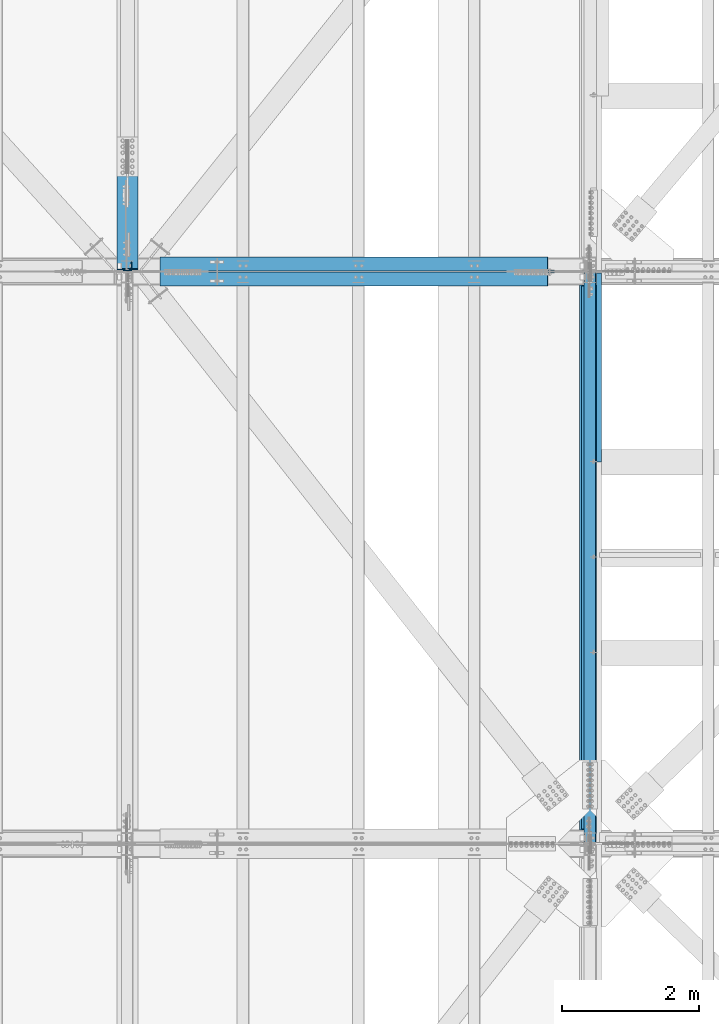
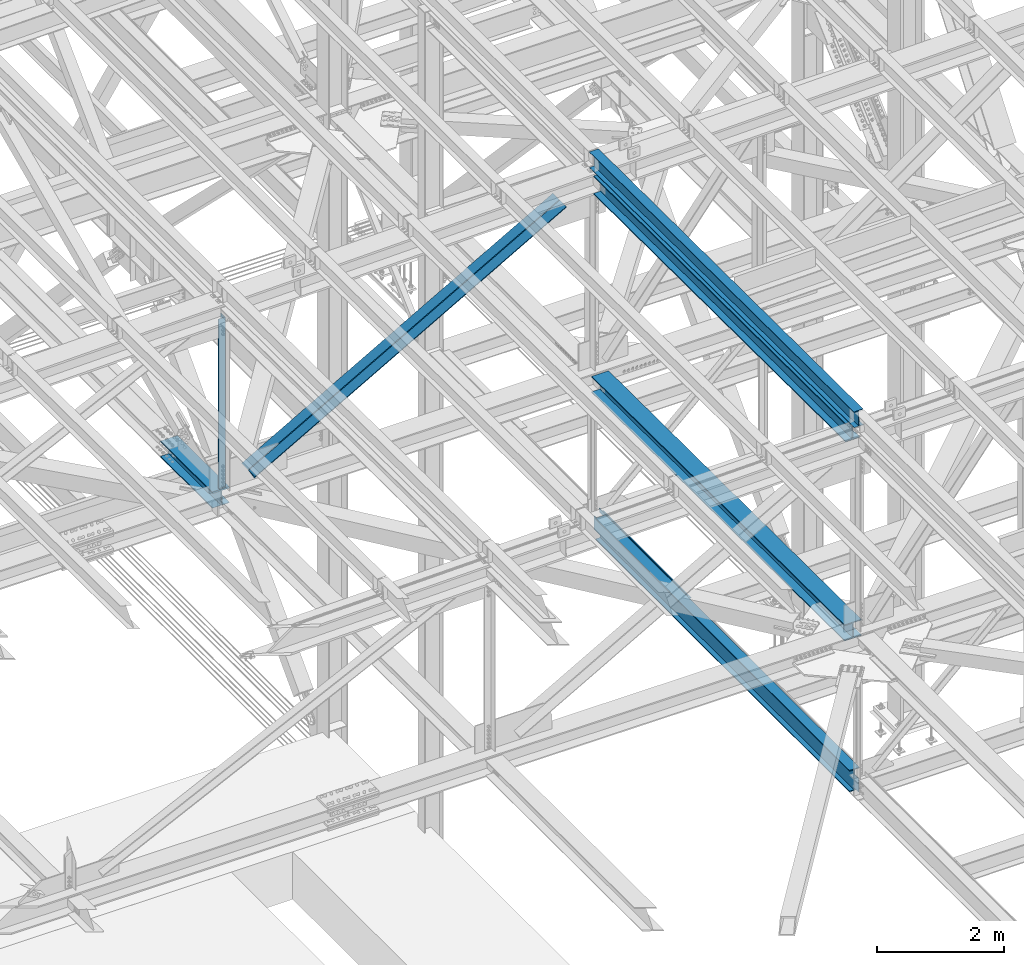
# One storey, part 1923 of 3843: 7 beams, 2 members, 9 elements without a shape of their own.
"""IFC2X3 building model written with IfcOpenShell, lengths in millimetres."""

from ifc_helpers import new_model, si_unit, frame, origin_with_axes, place, context, subcontext, project, spatial, faceted_brep, material, type_object, element, aggregate, save


model = new_model("IFC2X3")

# Units and contexts
model_context = context("Model", 3, precision=1e-05, world=origin_with_axes())
body_context = subcontext(model_context, "Body", "Model", "MODEL_VIEW")
ifc_project = project(units=[si_unit("LENGTHUNIT", "METRE", prefix="MILLI"), si_unit("AREAUNIT", "SQUARE_METRE"), si_unit("VOLUMEUNIT", "CUBIC_METRE"), si_unit("MASSUNIT", "GRAM", prefix="KILO"), si_unit("TIMEUNIT", "SECOND"), si_unit("PLANEANGLEUNIT", "RADIAN"), si_unit("SOLIDANGLEUNIT", "STERADIAN"), si_unit("THERMODYNAMICTEMPERATUREUNIT", "DEGREE_CELSIUS"), si_unit("LUMINOUSINTENSITYUNIT", "LUMEN")], contexts=[model_context])

# Site, building, storey
site_placement = place(None, origin_with_axes())
site = spatial("IfcSite", under=ifc_project, at=site_placement, CompositionType="ELEMENT")
building_placement = place(site_placement, origin_with_axes())
building = spatial("IfcBuilding", under=site, at=building_placement, Name="Undefined", CompositionType="ELEMENT")
storey_placement = place(building_placement, origin_with_axes())
storey = spatial("IfcBuildingStorey", under=building, at=storey_placement, Name="Undefined", CompositionType="ELEMENT", Elevation=0.0)

# Assembly, beam
assembly_1_placement = place(storey_placement, origin_with_axes())
assembly_1 = element("IfcElementAssembly", 1, at=assembly_1_placement, inside=storey, Name="BEAM", AssemblyPlace="NOTDEFINED", PredefinedType="RIGID_FRAME")
ifc_material_1 = material(Name="STEEL/A992")
beam_type_1 = type_object("IfcBeamType", Name="W12X26", PredefinedType="NOTDEFINED")
beam_1_placement = place(assembly_1_placement, frame((77009.5092619722, 75629.4962682345, 46502.463470033), z_axis=(-0.0211520979147317, 0.00640378100221278, 0.999755760344836), x_axis=(0.0, 0.999979486406387, -0.00640521400260297)))
beam_1 = element("IfcBeam", 2, at=beam_1_placement, type_object=beam_type_1, material=ifc_material_1, Name="BEAM", ObjectType="W12X26", context=body_context, shape_type="Brep", body=[
    faceted_brep([(12.7114449254441, 82.5500000002648, -155.574999999582), (12.650447660606, 82.5500000002939, -146.049999999595), (8344.02135411925, 82.5499999999302, -146.049999982184), (8344.08235138412, 82.549999999901, -155.574999982171), (12.6396934202057, 3.17499999985739, -146.049999999799), (8344.01059987888, 3.17499999947904, -146.049999982381), (10.7691106313287, 3.17500000016298, 146.049999999857), (8342.14001709, 3.17499999979918, 146.050000017276), (10.7798648717144, 82.5500000005995, 146.050000000068), (8342.15077133037, 82.5500000002357, 146.05000001748), (10.7188676068617, 82.5500000006141, 155.575000000055), (8342.08977406552, 82.5500000002503, 155.575000017474), (10.6964987868705, -82.5500000003085, 155.574999999641), (8342.06740524553, -82.5500000006723, 155.575000017052), (10.7574960517231, -82.5500000003231, 146.049999999654), (8342.12840251038, -82.5500000006869, 146.050000017065), (10.7682502920943, -3.17499999987194, 146.04999999985), (8342.13915675077, -3.17500000023574, 146.050000017269), (12.6388330809714, -3.17500000019209, -146.049999999806), (8344.00973953964, -3.17500000055588, -146.049999982388), (12.6280788406002, -82.5500000006286, -146.05000000001), (8343.99898529927, -82.5500000009924, -146.049999982599), (12.6890761054674, -82.5500000006432, -155.574999999997), (8344.05998256411, -82.550000001007, -155.574999982586)], [[[0, 1, 2, 3]], [[1, 4, 5, 2]], [[4, 6, 7, 5]], [[6, 8, 9, 7]], [[8, 10, 11, 9]], [[10, 12, 13, 11]], [[12, 14, 15, 13]], [[14, 16, 17, 15]], [[16, 18, 19, 17]], [[18, 20, 21, 19]], [[20, 22, 23, 21]], [[22, 0, 3, 23]], [[5, 7, 9, 11, 13, 15, 17, 19, 21, 23, 3, 2]], [[22, 20, 18, 16, 14, 12, 10, 8, 6, 4, 1, 0]]]),
])
aggregate(assembly_1, [beam_1])

assembly_2_placement = place(storey_placement, origin_with_axes())
assembly_2 = element("IfcElementAssembly", 3, at=assembly_2_placement, inside=storey, Name="BENT_PLATE", AssemblyPlace="NOTDEFINED", PredefinedType="RIGID_FRAME")
ifc_material_2 = material(Name="STEEL/A36")
beam_type_2 = type_object("IfcBeamType", PredefinedType="NOTDEFINED")
beam_2_placement = place(assembly_2_placement, frame((77179.4875000009, 82582.54475, 39627.1749999995), z_axis=(0.0, 1.0, 0.0), x_axis=(-1.0, 0.0, 0.0)))
beam_2 = element("IfcBeam", 4, at=beam_2_placement, type_object=beam_type_2, material=ifc_material_2, Name="BENT_PLATE", context=body_context, shape_type="Brep", body=[
    faceted_brep([(73.0250000006927, 0.0, -1382.7135), (69.8500000005442, 3.17500000000291, -1379.53850000001), (69.850000000617, 73.0249999994776, -1379.53850000001), (73.02500000078, 73.0249999994703, -1382.71249999999), (0.0, -7.27595761418343e-12, -1382.71249999999), (0.0, 3.17500000000291, -1379.53850000001), (69.8500000005442, 3.17500000000291, 1382.71249999999), (0.0, 3.17500000000291, 1382.71249999999), (0.0, -3.17500000000291, 1382.71249999999), (76.2000000005355, -3.17500000000291, 1382.71249999999), (76.2000000006228, 73.024999999463, 1382.71249999999), (69.850000000617, 73.0249999994776, 1382.71249999999), (0.0, -3.17500000000291, -1382.71249999999), (76.2000000005355, -3.17500000000291, -1382.71249999999), (76.2000000006228, 73.024999999463, -1382.71249999999)], [[[0, 1, 2, 3]], [[4, 5, 1, 0]], [[6, 7, 8, 9, 10, 11]], [[8, 12, 13, 9]], [[9, 13, 14, 10]], [[11, 10, 14, 3, 2]], [[6, 11, 2, 1]], [[7, 6, 1, 5]], [[12, 8, 7, 5, 4]], [[14, 13, 12, 4, 0, 3]]]),
])
aggregate(assembly_2, [beam_2])

assembly_3_placement = place(storey_placement, origin_with_axes())
assembly_3 = element("IfcElementAssembly", 5, at=assembly_3_placement, inside=storey, Name="BEAM", AssemblyPlace="NOTDEFINED", PredefinedType="RIGID_FRAME")
beam_type_3 = type_object("IfcBeamType", Name="W12X79", PredefinedType="NOTDEFINED")
beam_3_placement = place(assembly_3_placement, frame((70256.4, 83985.1, 42262.8114064772), z_axis=(0.0, 0.00197596199957479, 0.999998047785183), x_axis=(0.0, 0.999998047785183, -0.00197596199957261)))
beam_3 = element("IfcBeam", 6, at=beam_3_placement, type_object=beam_type_3, material=ifc_material_1, Name="BEAM", ObjectType="W12X79", context=body_context, shape_type="Brep", body=[
    faceted_brep([(19.5332032442384, 6.35000000000582, -131.762500001554), (6.83320324429951, -6.35000000000582, -119.062500001637), (6.83320324592933, -6.35000000000582, 119.062500002008), (19.5332032460574, 6.35000000000582, 131.762500001008), (25.8832032430073, 6.35000000000582, -138.112500000301), (25.8832032430073, 153.987500000003, -138.112500000301), (44.9332032442326, 153.987500000003, -157.162500000304), (44.9332032442326, -153.987500000003, -157.16250000157), (25.8832032430073, -153.987500000003, -138.112500000301), (25.8832032430073, -6.35000000000582, -138.112500000301), (1670.05327320425, -153.987500000003, 138.112500004296), (1670.05327320439, -153.987500000003, 157.162500004342), (44.9332032483362, -153.987500000003, 157.162500002676), (25.8832032460341, -153.987500000003, 138.112500000425), (1670.05327320439, 153.987500000003, 157.162500004342), (44.9332032483362, 153.987500000003, 157.162500000522), (1670.05327320425, 153.987500000003, 138.112500004296), (25.8832032460341, 153.987500000003, 138.112500000425), (1670.05327320425, 6.35000000000582, 138.112500004296), (25.8832032460341, 6.35000000000582, 138.112500000425), (25.8832032460341, -6.35000000000582, 138.112500000425), (1670.05327320425, -6.35000000000582, 138.112500004296), (1670.05327320224, 6.35000000000582, -138.112499996438), (1670.05327320224, -6.35000000000582, -138.112499996438), (1670.05327320224, -153.987500000003, -138.112499996438), (1670.05327320211, -153.987500000003, -157.162499996484), (1670.05327320211, 153.987500000003, -157.162499996484), (1670.05327320224, 153.987500000003, -138.112499996438)], [[[0, 1, 2, 3]], [[4, 5, 6, 7, 8, 9, 1, 0]], [[10, 11, 12, 13]], [[11, 14, 15, 12]], [[14, 16, 17, 15]], [[16, 18, 19, 17]], [[20, 13, 12, 15, 17, 19, 3, 2]], [[21, 10, 13, 20]], [[22, 18, 16, 14, 11, 10, 21, 23, 24, 25, 26, 27]], [[26, 25, 7, 6]], [[27, 26, 6, 5]], [[22, 27, 5, 4]], [[19, 18, 22, 4, 0, 3]], [[23, 21, 20, 2, 1, 9]], [[24, 23, 9, 8]], [[25, 24, 8, 7]]]),
])
aggregate(assembly_3, [beam_3])

assembly_4_placement = place(storey_placement, origin_with_axes())
assembly_4 = element("IfcElementAssembly", 7, at=assembly_4_placement, inside=storey, Name="BEAM", AssemblyPlace="NOTDEFINED", PredefinedType="RIGID_FRAME")
beam_4_placement = place(assembly_4_placement, frame((77012.8, 75628.5, 42319.6646336131), z_axis=(0.0, 0.00641290000094158, 0.999979437145374), x_axis=(0.0, 0.999979437145374, -0.00641290000093215)))
beam_4 = element("IfcBeam", 8, at=beam_4_placement, type_object=beam_type_3, material=ifc_material_1, Name="BEAM", ObjectType="W12X79", context=body_context, shape_type="Brep", body=[
    faceted_brep([(199.449468645718, 153.987500000003, -157.162500000471), (199.327300388424, 153.987500000003, -138.112500000439), (8159.2159783316, 153.987500000003, -138.112500009491), (8159.3381465889, 153.987500000003, -157.162500009523), (199.327300388424, 6.35000000000582, -138.112500000439), (8159.2159783316, 6.35000000000582, -138.112500009491), (197.555860657812, 6.35000000000582, 138.112499999996), (8157.444538601, 6.35000000000582, 138.112499990944), (197.555860657812, 153.987500000003, 138.112499999996), (8157.444538601, 153.987500000003, 138.112499990944), (197.433692400518, 153.987500000003, 157.16250000002), (8157.32237034373, 153.987500000003, 157.162499990969), (197.433692400518, -153.987500000003, 157.16250000002), (8157.32237034373, -153.987500000003, 157.162499990969), (197.555860657812, -153.987500000003, 138.112499999996), (8157.444538601, -153.987500000003, 138.112499990944), (197.555860657812, -6.35000000000582, 138.112499999996), (8157.444538601, -6.35000000000582, 138.112499990944), (199.327300388424, -6.35000000000582, -138.112500000439), (8159.2159783316, -6.35000000000582, -138.112500009491), (199.327300388424, -153.987500000003, -138.112500000439), (8159.2159783316, -153.987500000003, -138.112500009491), (199.449468645718, -153.987500000003, -157.162500000471), (8159.3381465889, -153.987500000003, -157.162500009523)], [[[0, 1, 2, 3]], [[1, 4, 5, 2]], [[4, 6, 7, 5]], [[6, 8, 9, 7]], [[8, 10, 11, 9]], [[10, 12, 13, 11]], [[12, 14, 15, 13]], [[14, 16, 17, 15]], [[16, 18, 19, 17]], [[18, 20, 21, 19]], [[20, 22, 23, 21]], [[22, 0, 3, 23]], [[5, 7, 9, 11, 13, 15, 17, 19, 21, 23, 3, 2]], [[22, 20, 18, 16, 14, 12, 10, 8, 6, 4, 1, 0]]]),
])
aggregate(assembly_4, [beam_4])

assembly_5_placement = place(storey_placement, origin_with_axes())
assembly_5 = element("IfcElementAssembly", 9, at=assembly_5_placement, inside=storey, Name="ANGLE", AssemblyPlace="NOTDEFINED", PredefinedType="RIGID_FRAME")
ifc_material_3 = material(Name="STEEL/A572-50")
beam_type_4 = type_object("IfcBeamType", Name="L5X5X3/8", PredefinedType="NOTDEFINED")
beam_5_placement = place(assembly_5_placement, frame((70256.4000021311, 84058.125, 45950.2996159815), z_axis=(-1.0, 0.0, 0.0), x_axis=(0.0, 0.0, -1.0)))
beam_5 = element("IfcBeam", 10, at=beam_5_placement, type_object=beam_type_4, material=ifc_material_3, Name="ANGLE", ObjectType="L5X5X3/8", context=body_context, shape_type="Brep", body=[
    faceted_brep([(223.003589676788, 63.5, -63.4999999990832), (223.004024525719, 63.5, 63.5000000009168), (3478.11515993929, 63.5, 63.5000000142027), (3478.11472509036, 63.5, -63.4999999857973), (223.004024525719, 53.9750000000058, 63.5000000009168), (3478.11515993929, 53.9750000000058, 63.5000000142027), (223.00362229046, 53.9750000000058, -53.9749999990745), (3478.11475770403, 53.9750000000058, -53.9749999858032), (223.00362229046, -63.5, -53.9749999990745), (3478.11475770403, -63.5, -53.9749999858032), (223.003589676788, -63.5, -63.4999999990832), (3478.11472509036, -63.5, -63.4999999857973)], [[[0, 1, 2, 3]], [[1, 4, 5, 2]], [[4, 6, 7, 5]], [[6, 8, 9, 7]], [[8, 10, 11, 9]], [[10, 0, 3, 11]], [[5, 7, 9, 11, 3, 2]], [[10, 8, 6, 4, 1, 0]]]),
])
aggregate(assembly_5, [beam_5])

# Assembly, member
assembly_6_placement = place(storey_placement, origin_with_axes())
assembly_6 = element("IfcElementAssembly", 11, at=assembly_6_placement, inside=storey, Name="ANGLE", AssemblyPlace="NOTDEFINED", PredefinedType="RIGID_FRAME")
member_type = type_object("IfcMemberType", Name="L8X8X1/2", PredefinedType="NOTDEFINED")
member_1_placement = place(assembly_6_placement, frame((77012.8, 84096.225, 46096.5034722281), z_axis=(0.0, 1.0, 0.0), x_axis=(-0.869739895059677, 0.0, -0.493510400033861)))
member_1 = element("IfcMember", 12, at=member_1_placement, type_object=member_type, material=ifc_material_3, Name="ANGLE", ObjectType="L8X8X1/2", context=body_context, shape_type="Brep", body=[
    faceted_brep([(656.750144484962, 101.600000001215, -101.600000000006), (656.750144484962, 101.600000001215, 101.600000000006), (7163.97970338727, 101.60000001306, 101.600000000006), (7163.97970338727, 101.60000001306, -101.600000000006), (656.750144484977, 88.9000000012029, 101.600000000006), (7163.97970338726, 88.9000000130627, 101.600000000006), (656.750144484977, 88.9000000012029, -88.8999999999942), (7163.97970338726, 88.9000000130627, -88.8999999999942), (656.750144484962, -101.599999998833, -88.8999999999942), (7163.97970338726, -101.599999986988, -88.8999999999942), (656.750144484962, -101.599999998833, -101.600000000006), (7163.97970338726, -101.599999986988, -101.600000000006)], [[[0, 1, 2, 3]], [[1, 4, 5, 2]], [[4, 6, 7, 5]], [[6, 8, 9, 7]], [[8, 10, 11, 9]], [[10, 0, 3, 11]], [[5, 7, 9, 11, 3, 2]], [[10, 8, 6, 4, 1, 0]]]),
])
aggregate(assembly_6, [member_1])

assembly_7_placement = place(storey_placement, origin_with_axes())
assembly_7 = element("IfcElementAssembly", 13, at=assembly_7_placement, inside=storey, Name="ANGLE", AssemblyPlace="NOTDEFINED", PredefinedType="RIGID_FRAME")
member_2_placement = place(assembly_7_placement, frame((70256.4, 83873.975, 42262.7668703415), z_axis=(0.0, -1.0, 0.0), x_axis=(0.869739895059675, 0.0, 0.493510400033864)))
member_2 = element("IfcMember", 14, at=member_2_placement, type_object=member_type, material=ifc_material_3, Name="ANGLE", ObjectType="L8X8X1/2", context=body_context, shape_type="Brep", body=[
    faceted_brep([(604.319807619017, 101.599999998929, -101.600000000006), (604.319807619017, 101.599999998929, 101.600000000006), (7111.54936652131, 101.599999987083, 101.600000000006), (7111.54936652131, 101.599999987083, -101.600000000006), (604.319807619002, 88.8999999989242, 101.600000000006), (7111.5493665213, 88.8999999870789, 101.600000000006), (604.319807619002, 88.8999999989242, -88.8999999999942), (7111.5493665213, 88.8999999870789, -88.8999999999942), (604.319807619017, -101.600000001127, -88.8999999999942), (7111.54936652131, -101.600000012972, -88.8999999999942), (604.319807619017, -101.600000001127, -101.600000000006), (7111.54936652131, -101.600000012972, -101.600000000006)], [[[0, 1, 2, 3]], [[1, 4, 5, 2]], [[4, 6, 7, 5]], [[6, 8, 9, 7]], [[8, 10, 11, 9]], [[10, 0, 3, 11]], [[5, 7, 9, 11, 3, 2]], [[10, 8, 6, 4, 1, 0]]]),
])
aggregate(assembly_7, [member_2])

# Assembly, beam
assembly_8_placement = place(storey_placement, origin_with_axes())
assembly_8 = element("IfcElementAssembly", 15, at=assembly_8_placement, inside=storey, Name="BEAM", AssemblyPlace="NOTDEFINED", PredefinedType="RIGID_FRAME")
beam_type_5 = type_object("IfcBeamType", Name="W14X68", PredefinedType="NOTDEFINED")
beam_6_placement = place(assembly_8_placement, frame((77012.8, 75628.5, 46150.0303815308), z_axis=(0.0, 0.00640521400260331, 0.999979486406387), x_axis=(0.0, 0.999979486406387, -0.00640521400260297)))
beam_6 = element("IfcBeam", 16, at=beam_6_placement, type_object=beam_type_5, material=ifc_material_1, Name="BEAM", ObjectType="W14X68", context=body_context, shape_type="Brep", body=[
    faceted_brep([(213.868234257025, 127.0, -177.799999999348), (213.746212427315, 127.0, -158.749999999374), (8145.05891224963, 127.0, -158.749999982792), (8145.18093407934, 127.0, -177.799999982766), (213.746212427315, 5.55624999999418, -158.749999999374), (8145.05891224963, 5.55624999999418, -158.749999982792), (211.712515265346, 5.55624999999418, 158.750000000262), (8143.02521508766, 5.55624999999418, 158.750000016837), (211.712515265346, 127.0, 158.750000000262), (8143.02521508766, 127.0, 158.750000016837), (211.590493435622, 127.0, 177.800000000243), (8142.90319325794, 127.0, 177.800000016818), (211.590493435622, -127.0, 177.800000000243), (8142.90319325794, -127.0, 177.800000016818), (211.712515265346, -127.0, 158.750000000262), (8143.02521508766, -127.0, 158.750000016837), (211.712515265346, -5.55624999999418, 158.750000000262), (8143.02521508766, -5.55624999999418, 158.750000016837), (213.746212427315, -5.55624999999418, -158.749999999374), (8145.05891224963, -5.55624999999418, -158.749999982792), (213.746212427315, -127.0, -158.749999999374), (8145.05891224963, -127.0, -158.749999982792), (213.868234257025, -127.0, -177.799999999348), (8145.18093407934, -127.0, -177.799999982766)], [[[0, 1, 2, 3]], [[1, 4, 5, 2]], [[4, 6, 7, 5]], [[6, 8, 9, 7]], [[8, 10, 11, 9]], [[10, 12, 13, 11]], [[12, 14, 15, 13]], [[14, 16, 17, 15]], [[16, 18, 19, 17]], [[18, 20, 21, 19]], [[20, 22, 23, 21]], [[22, 0, 3, 23]], [[5, 7, 9, 11, 13, 15, 17, 19, 21, 23, 3, 2]], [[22, 20, 18, 16, 14, 12, 10, 8, 6, 4, 1, 0]]]),
])
aggregate(assembly_8, [beam_6])

assembly_9_placement = place(storey_placement, origin_with_axes())
assembly_9 = element("IfcElementAssembly", 17, at=assembly_9_placement, inside=storey, Name="BEAM", AssemblyPlace="NOTDEFINED", PredefinedType="RIGID_FRAME")
beam_type_6 = type_object("IfcBeamType", Name="W16X57", PredefinedType="NOTDEFINED")
beam_7_placement = place(assembly_9_placement, frame((77012.8, 75628.5, 39476.3625), z_axis=(0.0, 0.0, 1.0), x_axis=(0.0, 1.0, 0.0)))
beam_7 = element("IfcBeam", 18, at=beam_7_placement, type_object=beam_type_6, material=ifc_material_1, Name="BEAM", ObjectType="W16X57", context=body_context, shape_type="Brep", body=[
    faceted_brep([(8147.84375000001, -5.55624999999418, -190.5), (8147.84375000001, -90.4875000000029, -190.5), (8147.84375000001, -90.4875000000029, -207.962500000001), (8147.84375000001, 90.4875000000029, -207.962500000001), (8147.84375000001, 90.4875000000029, -190.5), (8147.84375000001, 5.55624999999418, -190.5), (8147.84375000001, 5.55624999999418, -169.862499809249), (8147.84375000001, -5.55624999999418, -169.862499809249), (8148.8104799226, 5.55624999999418, -165.002420291203), (8148.8104799226, -5.55624999999418, -165.002420291203), (8151.56349382308, 5.55624999999418, -160.882243823049), (8151.56349382308, -5.55624999999418, -160.882243823049), (8155.68367029124, 5.55624999999418, -158.129229922575), (8155.68367029124, -5.55624999999418, -158.129229922575), (8160.54374980928, 5.55624999999418, -157.162499999984), (8160.54374980928, -5.55624999999418, -157.162499999984), (8338.34375000001, -5.55624999999418, -157.162499999984), (8338.34375000001, 5.55624999999418, -157.162499999984), (151.606250000026, 5.55624999999418, 190.5), (151.606250000026, 90.4875000000029, 190.5), (8147.84375000001, 90.4875000000029, 190.5), (8147.84375000001, 5.55624999999418, 190.5), (151.606250000026, -5.55624999999418, -170.122499798665), (151.606250000026, 5.55624999999418, -170.122499798665), (151.606250000026, 5.55624999999418, -190.5), (151.606250000026, 90.4875000000029, -190.5), (151.606250000026, 90.4875000000029, -207.962500000001), (151.606250000026, -90.4875000000029, -207.962500000001), (151.606250000026, -90.4875000000029, -190.5), (151.606250000026, -5.55624999999418, -190.5), (150.639520077442, -5.55624999999418, -165.262420280618), (150.639520077442, 5.55624999999418, -165.262420280618), (147.886506176961, -5.55624999999418, -161.142243812465), (147.886506176961, 5.55624999999418, -161.142243812465), (143.7663297088, -5.55624999999418, -158.389229911991), (143.7663297088, 5.55624999999418, -158.389229911991), (138.906250190761, -5.55624999999418, -157.4224999894), (138.906250190761, 5.55624999999418, -157.4224999894), (18.2562499999913, -5.55624999999418, -157.4224999894), (18.2562499999913, 5.55624999999418, -157.4224999894), (18.2562499999913, -5.55624999999418, 106.102500010602), (18.2562499999913, 5.55624999999418, 106.102500010602), (138.906250190761, -5.55624999999418, 106.102500010602), (138.906250190761, 5.55624999999418, 106.102500010602), (143.7663297088, -5.55624999999418, 107.069229933193), (143.7663297088, 5.55624999999418, 107.069229933193), (147.886506176961, -5.55624999999418, 109.822243833667), (147.886506176961, 5.55624999999418, 109.822243833667), (150.639520077442, -5.55624999999418, 113.942420301821), (150.639520077442, 5.55624999999418, 113.942420301821), (151.606250000026, -5.55624999999418, 118.802499819867), (151.606250000026, 5.55624999999418, 118.802499819867), (151.606250000026, -90.4875000000029, 207.962500000001), (151.606250000026, 90.4875000000029, 207.962500000001), (151.606250000026, -5.55624999999418, 190.5), (151.606250000026, -90.4875000000029, 190.5), (8147.84375000001, -5.55624999999418, 190.5), (8147.84375000001, -90.4875000000029, 190.5), (8147.84375000001, -90.4875000000029, 207.962500000001), (8147.84375000001, 90.4875000000029, 207.962500000001), (8147.84375000001, -5.55624999999418, 119.062499793275), (8147.84375000001, 5.55624999999418, 119.062499793275), (8148.8104799226, -5.55624999999418, 114.202420275229), (8148.8104799226, 5.55624999999418, 114.202420275229), (8151.56349382308, -5.55624999999418, 110.082243807075), (8151.56349382308, 5.55624999999418, 110.082243807075), (8155.68367029124, -5.55624999999418, 107.329229906602), (8155.68367029124, 5.55624999999418, 107.329229906602), (8160.54374980928, -5.55624999999418, 106.36249998401), (8160.54374980928, 5.55624999999418, 106.36249998401), (8338.34375000001, -5.55624999999418, 106.36249998401), (8338.34375000001, 5.55624999999418, 106.36249998401), (8338.34375000001, -5.55624999999418, 93.6625000005661), (8338.34375000001, -5.55624999999418, -136.937499999432)], [[[0, 1, 2, 3, 4, 5, 6, 7]], [[7, 6, 8, 9]], [[9, 8, 10, 11]], [[11, 10, 12, 13]], [[13, 12, 14, 15]], [[16, 15, 14, 17]], [[18, 19, 20, 21]], [[22, 23, 24, 25, 26, 27, 28, 29]], [[30, 31, 23, 22]], [[32, 33, 31, 30]], [[34, 35, 33, 32]], [[36, 37, 35, 34]], [[38, 39, 37, 36]], [[40, 41, 39, 38]], [[42, 43, 41, 40]], [[44, 45, 43, 42]], [[46, 47, 45, 44]], [[48, 49, 47, 46]], [[50, 51, 49, 48]], [[52, 53, 19, 18, 51, 50, 54, 55]], [[55, 54, 56, 57]], [[52, 55, 57, 58]], [[53, 52, 58, 59]], [[19, 53, 59, 20]], [[58, 57, 56, 60, 61, 21, 20, 59]], [[62, 63, 61, 60]], [[64, 65, 63, 62]], [[66, 67, 65, 64]], [[68, 69, 67, 66]], [[70, 71, 69, 68]], [[71, 70, 72, 73, 16, 17]], [[12, 10, 8, 6, 5, 24, 23, 31, 33, 35, 37, 39, 41, 43, 45, 47, 49, 51, 18, 21, 61, 63, 65, 67, 69, 71, 17, 14]], [[25, 24, 5, 4]], [[26, 25, 4, 3]], [[27, 26, 3, 2]], [[28, 27, 2, 1]], [[29, 28, 1, 0]], [[73, 72, 70, 68, 66, 64, 62, 60, 56, 54, 50, 48, 46, 44, 42, 40, 38, 36, 34, 32, 30, 22, 29, 0, 7, 9, 11, 13, 15, 16]]]),
])
aggregate(assembly_9, [beam_7])

save(model, "model.ifc")
